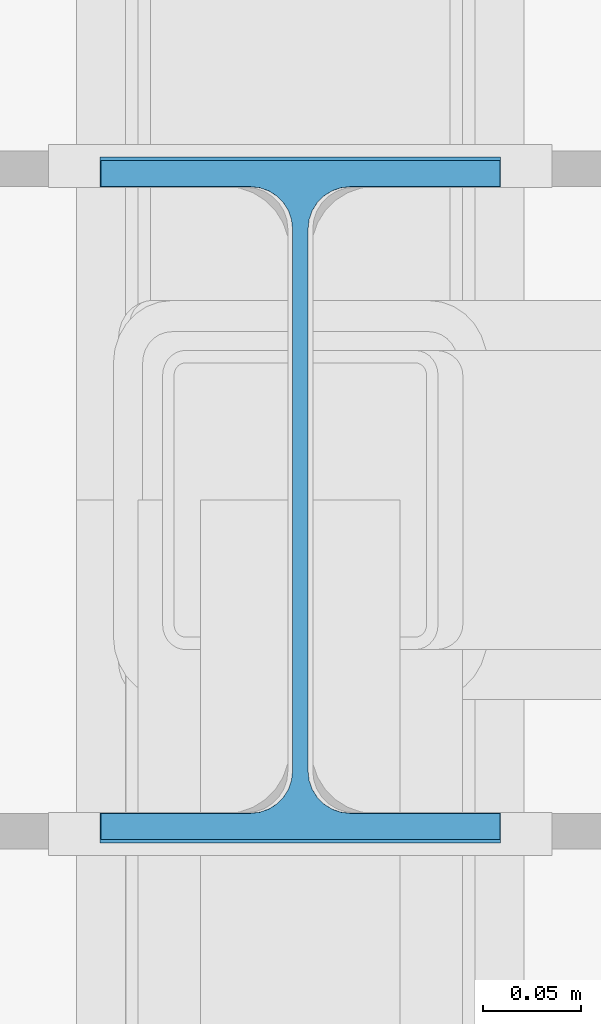
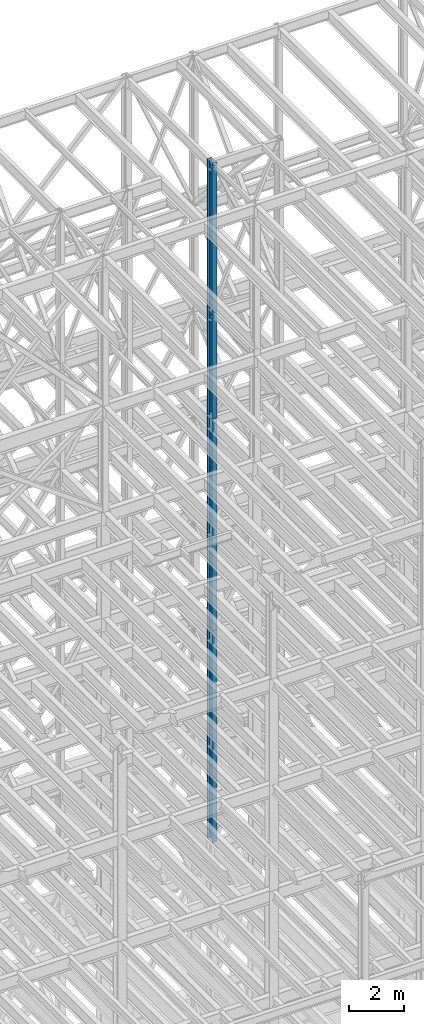
# One storey, part 92 of 150: 3 columns.
"""IFC2X3 building model written with IfcOpenShell, lengths in millimetres."""

import ifcopenshell
import ifcopenshell.guid

model = None  # the IFC model being written
_history = None  # IfcOwnerHistory: only IFC2X3 demands one
_inside = {}  # id of a spatial element -> (the spatial element, [elements in it])
_under = {}  # id of a project, library or spatial element -> (it, [spatial elements below it])
_declared = {}  # id of a project -> (the project, [libraries it declares])
_typed = {}  # id of a type object -> (the type object, [elements of that type])
_made_of = {}  # id of a material, layer set ... -> (it, [elements and type objects made of it])


def new_model(schema):
    """Start an empty IFC model of exactly this schema.

    Asked for "IFC4X3", IfcOpenShell would pick the latest addendum, in which some entities
    have other attributes; the version numbers below select the first issue.
    IFC2X3 requires an IfcOwnerHistory on every rooted entity: one is made here for all.
    """
    global model, _history
    if schema == "IFC4X3":
        model = ifcopenshell.file(schema_version=(4, 3, 0, 0))
    else:
        model = ifcopenshell.file(schema=schema)
    _inside.clear()
    _under.clear()
    _declared.clear()
    _typed.clear()
    _made_of.clear()
    _history = None
    if model.schema == "IFC2X3":
        org = make("IfcOrganization", Name="unknown")
        user = make(
            "IfcPersonAndOrganization",
            ThePerson=make("IfcPerson", FamilyName="unknown"),
            TheOrganization=org,
        )
        app = make(
            "IfcApplication",
            ApplicationDeveloper=org,
            Version="unknown",
            ApplicationFullName="unknown",
            ApplicationIdentifier="unknown",
        )
        _history = make(
            "IfcOwnerHistory",
            OwningUser=user,
            OwningApplication=app,
            ChangeAction="ADDED",
            CreationDate=0,
        )
    return model


def make(cls, **values):
    """One entity of the class cls with the attributes given. An attribute that is None is left unset."""
    return model.create_entity(
        cls, **{name: value for name, value in values.items() if value is not None}
    )


def rooted(cls, **values):
    """An entity with a GlobalId (a new one), such as an element, a storey or a relation."""
    return make(cls, GlobalId=ifcopenshell.guid.new(), OwnerHistory=_history, **values)


def si_unit(unit_type, name, prefix=None):
    """IfcSIUnit, for example si_unit("LENGTHUNIT", "METRE", prefix="MILLI")."""
    return make("IfcSIUnit", UnitType=unit_type, Prefix=prefix, Name=name)


def assignment(units):
    """IfcUnitAssignment: the units of a project."""
    return None if units is None else make("IfcUnitAssignment", Units=units)


def point(xyz):
    """IfcCartesianPoint."""
    return None if xyz is None else make("IfcCartesianPoint", Coordinates=xyz)


def direction(xyz):
    """IfcDirection."""
    return None if xyz is None else make("IfcDirection", DirectionRatios=xyz)


def frame(location, z_axis=None, x_axis=None):
    """IfcAxis2Placement3D, a coordinate frame: its origin and axes. An axis left out is left unset."""
    return make(
        "IfcAxis2Placement3D",
        Location=point(location),
        Axis=direction(z_axis),
        RefDirection=direction(x_axis),
    )


def frame_2d(location, x_axis=None):
    """IfcAxis2Placement2D, a coordinate frame in the plane: its origin and x axis."""
    return make(
        "IfcAxis2Placement2D", Location=point(location), RefDirection=direction(x_axis)
    )


def origin_with_axes():
    """The frame at (0, 0, 0) with the z axis (0, 0, 1) and the x axis (1, 0, 0) written out."""
    return frame((0.0, 0.0, 0.0), z_axis=(0.0, 0.0, 1.0), x_axis=(1.0, 0.0, 0.0))


def origin_2d_with_axis():
    """The frame at (0, 0) in the plane with the x axis (1, 0) written out."""
    return frame_2d((0.0, 0.0), x_axis=(1.0, 0.0))


def place(relative_to, where):
    """IfcLocalPlacement: puts the frame where relative to a parent placement (None: the world)."""
    return make(
        "IfcLocalPlacement", PlacementRelTo=relative_to, RelativePlacement=where
    )


def context(
    kind, dimensions, precision=None, world=None, true_north=None, identifier=None
):
    """IfcGeometricRepresentationContext, for example the 3D "Model" context."""
    return make(
        "IfcGeometricRepresentationContext",
        ContextIdentifier=identifier,
        ContextType=kind,
        CoordinateSpaceDimension=dimensions,
        Precision=precision,
        WorldCoordinateSystem=world,
        TrueNorth=true_north,
    )


def subcontext(parent, identifier, kind, view, scale=None):
    """IfcGeometricRepresentationSubContext, for example "Body" below "Model"."""
    return make(
        "IfcGeometricRepresentationSubContext",
        ContextIdentifier=identifier,
        ContextType=kind,
        ParentContext=parent,
        TargetScale=scale,
        TargetView=view,
    )


def project(units=None, contexts=None):
    """IfcProject with its units and contexts."""
    return rooted(
        "IfcProject",
        Name="project",
        RepresentationContexts=contexts,
        UnitsInContext=assignment(units),
    )


def spatial(cls, under=None, at=None, **own):
    """A site, building, storey or space (cls), placed at a placement, below another one or the project."""
    s = rooted(cls, ObjectPlacement=at, **own)
    if under is not None:
        _under.setdefault(under.id(), (under, []))[1].append(s)
    return s


def profile(cls, at=None, kind="AREA", **sizes):
    """A parametric profile (cls). Its sizes go by their IFC names, for example OverallWidth=200.0."""
    return make(cls, ProfileType=kind, Position=at, **sizes)


def i_section(**sizes):
    """IfcIShapeProfileDef."""
    return profile("IfcIShapeProfileDef", **sizes)


def extrude(swept, where, along, depth):
    """IfcExtrudedAreaSolid: the profile swept, set in the frame where, extruded along a direction by depth."""
    return make(
        "IfcExtrudedAreaSolid",
        SweptArea=swept,
        Position=where,
        ExtrudedDirection=direction(along),
        Depth=depth,
    )


def shape(context_of_items, identifier, shape_type, items):
    """IfcShapeRepresentation: the items that make up one representation, for example the "Body"."""
    return make(
        "IfcShapeRepresentation",
        ContextOfItems=context_of_items,
        RepresentationIdentifier=identifier,
        RepresentationType=shape_type,
        Items=items,
    )


def material(Name=None, Category=None):
    """IfcMaterial."""
    return make("IfcMaterial", Name=Name, Category=Category)


def made_of(thing, what):
    """Note that an element or type object is made of a material, layer set ...; save() writes the relation."""
    if what is not None:
        _made_of.setdefault(what.id(), (what, []))[1].append(thing)
    return thing


def type_object(cls, material=None, **own):
    """A type object (cls), such as IfcWallType, which elements share."""
    return made_of(rooted(cls, **own), material)


def element(
    cls,
    number,
    at=None,
    inside=None,
    cuts=None,
    type_object=None,
    material=None,
    context=None,
    identifier="Body",
    shape_type=None,
    held_by="IfcProductDefinitionShape",
    body=None,
    shapes=None,
    **own,
):
    """One element of the class cls, such as IfcWall. Its Tag is "e" and its number.

    at: its placement. inside: the storey or other place that contains it. cuts: it is an
    opening in that element (IfcRelVoidsElement). A single representation is given by context,
    identifier, shape_type and body (its items); several are given by shapes. held_by: the class
    of the entity that holds the representations. save() writes the other relations.
    """
    e = rooted(cls, Tag="e%d" % number, ObjectPlacement=at, **own)
    if body is not None:
        shapes = [shape(context, identifier, shape_type, body)]
    if shapes is not None:
        e.Representation = make(held_by, Representations=shapes)
    if inside is not None:
        _inside.setdefault(inside.id(), (inside, []))[1].append(e)
    if cuts is not None:
        rooted(
            "IfcRelVoidsElement", RelatingBuildingElement=cuts, RelatedOpeningElement=e
        )
    if type_object is not None:
        _typed.setdefault(type_object.id(), (type_object, []))[1].append(e)
    return made_of(e, material)


def aggregate(whole, parts):
    """IfcRelAggregates: a whole, such as a stair, and the parts it consists of."""
    return rooted("IfcRelAggregates", RelatingObject=whole, RelatedObjects=parts)


def save(model, path):
    """Write the relations noted so far, then the file.

    IfcRelAggregates (storeys below a building ...), IfcRelContainedInSpatialStructure (elements
    in a storey), IfcRelDefinesByType, IfcRelAssociatesMaterial and IfcRelDeclares: one each for
    every whole, place, type object, material and project.
    """
    for whole, parts in _under.values():
        aggregate(whole, parts)
    for where, things in _inside.values():
        rooted(
            "IfcRelContainedInSpatialStructure",
            RelatedElements=things,
            RelatingStructure=where,
        )
    for kind, things in _typed.values():
        rooted("IfcRelDefinesByType", RelatedObjects=things, RelatingType=kind)
    for what, things in _made_of.values():
        rooted("IfcRelAssociatesMaterial", RelatedObjects=things, RelatingMaterial=what)
    for by, libraries in _declared.values():
        rooted("IfcRelDeclares", RelatingContext=by, RelatedDefinitions=libraries)
    model.write(path)


model = new_model("IFC2X3")

# Units and contexts
model_context = context("Model", 3, precision=1e-05, world=origin_with_axes())
body_context = subcontext(model_context, "Body", "Model", "MODEL_VIEW")
ifc_project = project(units=[si_unit("LENGTHUNIT", "METRE", prefix="MILLI"), si_unit("AREAUNIT", "SQUARE_METRE"), si_unit("VOLUMEUNIT", "CUBIC_METRE"), si_unit("MASSUNIT", "GRAM", prefix="KILO"), si_unit("TIMEUNIT", "SECOND"), si_unit("PLANEANGLEUNIT", "RADIAN"), si_unit("SOLIDANGLEUNIT", "STERADIAN"), si_unit("THERMODYNAMICTEMPERATUREUNIT", "DEGREE_CELSIUS"), si_unit("LUMINOUSINTENSITYUNIT", "LUMEN")], contexts=[model_context])

# Site, building, storey
site_placement = place(None, origin_with_axes())
site = spatial("IfcSite", under=ifc_project, at=site_placement, CompositionType="ELEMENT")
building_placement = place(site_placement, origin_with_axes())
building = spatial("IfcBuilding", under=site, at=building_placement, Name="Undefined", CompositionType="ELEMENT")
storey_placement = place(building_placement, origin_with_axes())
storey = spatial("IfcBuildingStorey", under=building, at=storey_placement, Name="Undefined", CompositionType="ELEMENT", Elevation=0.0)

# Columns
ifc_material = material(Name="STEEL/A992")
column_type_1 = type_object("IfcColumnType", Name="W14X43", PredefinedType="NOTDEFINED")
column_1_placement = place(storey_placement, frame((62992.0, 25628.6, 54483.001143), z_axis=(0.0, 0.0, 1.0), x_axis=(1.0, 0.0, 0.0)))
element("IfcColumn", 1, at=column_1_placement, inside=storey, type_object=column_type_1, material=ifc_material, Name="COLUMN", ObjectType="W14X43", context=body_context, shape_type="SweptSolid", body=[
    extrude(i_section(OverallWidth=203.2, OverallDepth=346.075, WebThickness=7.9375, FlangeThickness=13.462, FilletRadius=21.4629, at=origin_2d_with_axis()), frame((0.0, 0.0, 11429.998857), z_axis=(0.0, 0.0, -1.0), x_axis=(-1.0, 0.0, 0.0)), (0.0, 0.0, 1.0), 11429.998857),
])
column_2_placement = place(storey_placement, frame((62992.0, 25628.6, 45034.201143), z_axis=(0.0, 0.0, 1.0), x_axis=(1.0, 0.0, 0.0)))
element("IfcColumn", 2, at=column_2_placement, inside=storey, type_object=column_type_1, material=ifc_material, Name="COLUMN", ObjectType="W14X43", context=body_context, shape_type="SweptSolid", body=[
    extrude(i_section(OverallWidth=203.2, OverallDepth=346.075, WebThickness=7.9375, FlangeThickness=13.462, FilletRadius=21.4629, at=origin_2d_with_axis()), frame((0.0, 0.0, 9448.8), z_axis=(0.0, 0.0, -1.0), x_axis=(-1.0, 0.0, 0.0)), (0.0, 0.0, 1.0), 9448.8),
])
column_type_2 = type_object("IfcColumnType", Name="W14X48", PredefinedType="NOTDEFINED")
column_3_placement = place(storey_placement, frame((62992.0, 25628.6, 35585.401143), z_axis=(0.0, 0.0, 1.0), x_axis=(1.0, 0.0, 0.0)))
element("IfcColumn", 3, at=column_3_placement, inside=storey, type_object=column_type_2, material=ifc_material, Name="COLUMN", ObjectType="W14X48", context=body_context, shape_type="SweptSolid", body=[
    extrude(i_section(OverallWidth=203.962, OverallDepth=349.25, WebThickness=7.9375, FlangeThickness=15.113, FilletRadius=21.3994, at=origin_2d_with_axis()), frame((0.0, 0.0, 9448.8), z_axis=(0.0, 0.0, -1.0), x_axis=(-1.0, 0.0, 0.0)), (0.0, 0.0, 1.0), 9448.8),
])

save(model, "model.ifc")
